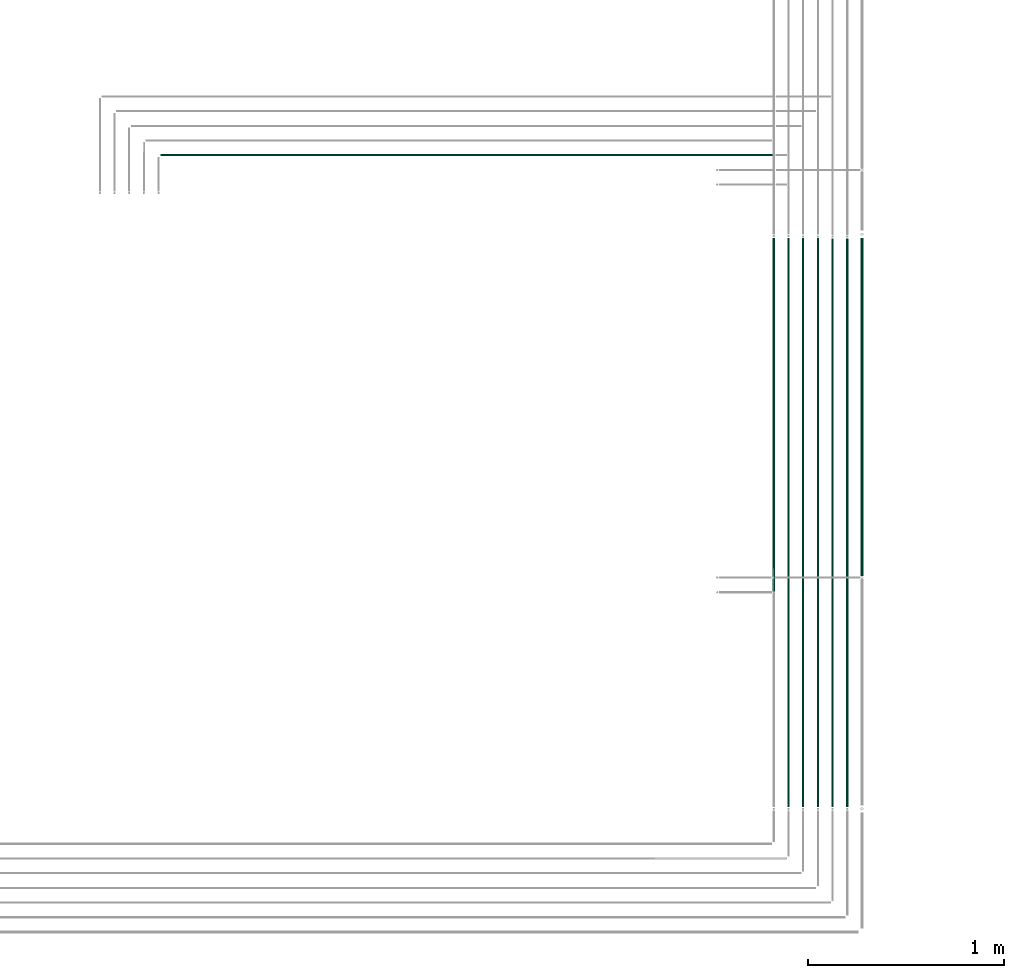
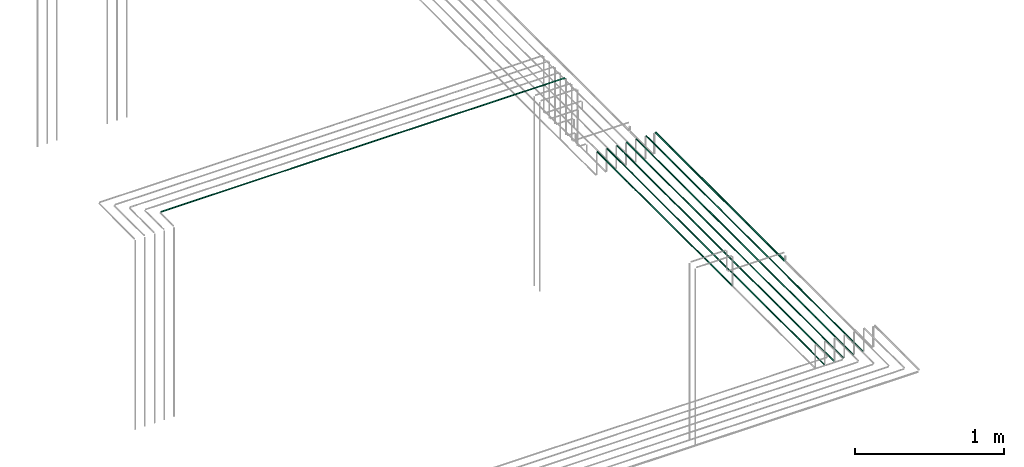
# One storey, part 18 of 89: 8 flow segments.
"""IFC2X3 building model written with IfcOpenShell, lengths in millimetres."""

from ifc_helpers import new_model, entity, si_unit, converted_unit, derived_unit, direction, frame, frame_2d, origin, origin_2d_with_axis, place, context, subcontext, project, spatial, circle, extrude, type_object, element, save


model = new_model("IFC2X3")

# Units and contexts
model_context = context("Model", 3, precision=0.01, world=origin(), true_north=direction((6.12303176911189e-17, 1.0)))
body_context = subcontext(model_context, "Body", "Model", "MODEL_VIEW")
ifc_project = project(units=[si_unit("LENGTHUNIT", "METRE", prefix="MILLI"), si_unit("AREAUNIT", "SQUARE_METRE"), si_unit("VOLUMEUNIT", "CUBIC_METRE"), converted_unit("PLANEANGLEUNIT", "DEGREE", entity("IfcRatioMeasure", 0.0174532925199433), si_unit("PLANEANGLEUNIT", "RADIAN"), dimensions=[0, 0, 0, 0, 0, 0, 0]), si_unit("MASSUNIT", "GRAM", prefix="KILO"), derived_unit("MASSDENSITYUNIT", [(si_unit("MASSUNIT", "GRAM", prefix="KILO"), 1), (si_unit("LENGTHUNIT", "METRE"), -3)]), derived_unit("MOMENTOFINERTIAUNIT", [(si_unit("LENGTHUNIT", "METRE"), 4)]), si_unit("TIMEUNIT", "SECOND"), si_unit("FREQUENCYUNIT", "HERTZ"), si_unit("THERMODYNAMICTEMPERATUREUNIT", "DEGREE_CELSIUS"), derived_unit("THERMALTRANSMITTANCEUNIT", [(si_unit("MASSUNIT", "GRAM", prefix="KILO"), 1), (si_unit("THERMODYNAMICTEMPERATUREUNIT", "KELVIN"), -1), (si_unit("TIMEUNIT", "SECOND"), -3)]), derived_unit("VOLUMETRICFLOWRATEUNIT", [(si_unit("LENGTHUNIT", "METRE"), 3), (si_unit("TIMEUNIT", "SECOND"), -1)]), derived_unit("MASSFLOWRATEUNIT", [(si_unit("MASSUNIT", "GRAM", prefix="KILO"), 1), (si_unit("TIMEUNIT", "SECOND"), -1)]), derived_unit("ROTATIONALFREQUENCYUNIT", [(si_unit("TIMEUNIT", "SECOND"), -1)]), si_unit("ELECTRICCURRENTUNIT", "AMPERE"), si_unit("ELECTRICVOLTAGEUNIT", "VOLT"), si_unit("POWERUNIT", "WATT"), si_unit("FORCEUNIT", "NEWTON", prefix="KILO"), si_unit("ILLUMINANCEUNIT", "LUX"), si_unit("LUMINOUSFLUXUNIT", "LUMEN"), si_unit("LUMINOUSINTENSITYUNIT", "CANDELA"), derived_unit("USERDEFINED", [(si_unit("MASSUNIT", "GRAM", prefix="KILO"), -1), (si_unit("LENGTHUNIT", "METRE"), -2), (si_unit("TIMEUNIT", "SECOND"), 3), (si_unit("LUMINOUSFLUXUNIT", "LUMEN"), 1)]), derived_unit("LINEARVELOCITYUNIT", [(si_unit("LENGTHUNIT", "METRE"), 1), (si_unit("TIMEUNIT", "SECOND"), -1)]), si_unit("PRESSUREUNIT", "PASCAL"), derived_unit("USERDEFINED", [(si_unit("LENGTHUNIT", "METRE"), -2), (si_unit("MASSUNIT", "GRAM", prefix="KILO"), 1), (si_unit("TIMEUNIT", "SECOND"), -2)]), derived_unit("LINEARFORCEUNIT", [(si_unit("MASSUNIT", "GRAM", prefix="KILO"), 1), (si_unit("LENGTHUNIT", "METRE"), 1), (si_unit("TIMEUNIT", "SECOND"), -2), (si_unit("LENGTHUNIT", "METRE"), -1)]), derived_unit("PLANARFORCEUNIT", [(si_unit("MASSUNIT", "GRAM", prefix="KILO"), 1), (si_unit("LENGTHUNIT", "METRE"), 1), (si_unit("TIMEUNIT", "SECOND"), -2), (si_unit("LENGTHUNIT", "METRE"), -2)])], contexts=[model_context])

# Site, building, storey
site_placement = place(None, frame((0.0, -0.00077364408347762, 0.0)))
site = spatial("IfcSite", under=ifc_project, at=site_placement, CompositionType="ELEMENT")
building_placement = place(site_placement, origin())
building = spatial("IfcBuilding", under=site, at=building_placement, CompositionType="ELEMENT")
storey_placement = place(building_placement, frame((0.0, 0.0, 24000.0)))
storey = spatial("IfcBuildingStorey", under=building, at=storey_placement, CompositionType="ELEMENT", Elevation=24000.0)

# Flow segments
pipe_segment_type = type_object("IfcPipeSegmentType", PredefinedType="NOTDEFINED")
flow_segment_1_placement = place(storey_placement, frame((67289.4049963189, 1813.24057780393, 2794.40472776409)))
element("IfcFlowSegment", 1, at=flow_segment_1_placement, inside=storey, type_object=pipe_segment_type, context=body_context, shape_type="SweptSolid", body=[
    extrude(circle(Radius=4.0, at=frame_2d((8.66293703438714e-12, 0.0), x_axis=(1.0, 0.0))), frame((5.59527223591499, 0.0, 5.59527223591499), z_axis=(0.0, 1.0, 0.0), x_axis=(-1.0, 0.0, 0.0)), (0.0, 0.0, 1.0), 2902.18521069678),
])
flow_segment_2_placement = place(storey_placement, frame((67364.4049963189, 1813.24057780393, 2794.40472776409)))
element("IfcFlowSegment", 2, at=flow_segment_2_placement, inside=storey, type_object=pipe_segment_type, context=body_context, shape_type="SweptSolid", body=[
    extrude(circle(Radius=4.0, at=origin_2d_with_axis()), frame((5.59527223591499, 0.0, 5.59527223591499), z_axis=(0.0, 1.0, 0.0), x_axis=(-1.0, 0.0, 0.0)), (0.0, 0.0, 1.0), 2900.36521628995),
])
flow_segment_3_placement = place(storey_placement, frame((67439.4049963189, 1813.24057780393, 2794.40472776409)))
element("IfcFlowSegment", 3, at=flow_segment_3_placement, inside=storey, type_object=pipe_segment_type, context=body_context, shape_type="SweptSolid", body=[
    extrude(circle(Radius=4.0, at=frame_2d((8.66293703438714e-12, 0.0), x_axis=(1.0, 0.0))), frame((5.59527223591499, 0.0, 5.59527223591499), z_axis=(0.0, 1.0, 0.0), x_axis=(-1.0, 0.0, 0.0)), (0.0, 0.0, 1.0), 2900.36521628995),
])
flow_segment_4_placement = place(storey_placement, frame((67514.4049963189, 1813.24057780393, 2794.40472776409)))
element("IfcFlowSegment", 4, at=flow_segment_4_placement, inside=storey, type_object=pipe_segment_type, context=body_context, shape_type="SweptSolid", body=[
    extrude(circle(Radius=4.0, at=frame_2d((8.66293703438714e-12, 0.0), x_axis=(1.0, 0.0))), frame((5.59527223591499, 0.0, 5.59527223591499), z_axis=(0.0, 1.0, 0.0), x_axis=(-1.0, 0.0, 0.0)), (0.0, 0.0, 1.0), 2899.45521908654),
])
flow_segment_5_placement = place(storey_placement, frame((67589.4049963189, 1813.24057780393, 2794.40472776409)))
element("IfcFlowSegment", 5, at=flow_segment_5_placement, inside=storey, type_object=pipe_segment_type, context=body_context, shape_type="SweptSolid", body=[
    extrude(circle(Radius=4.0, at=frame_2d((8.66293703438714e-12, 0.0), x_axis=(1.0, 0.0))), frame((5.59527223592365, 0.0, 5.59527223591499), z_axis=(0.0, 1.0, 0.0), x_axis=(-1.0, 0.0, 0.0)), (0.0, 0.0, 1.0), 2899.45521908654),
])
flow_segment_6_placement = place(storey_placement, frame((64091.1933873496, 5132.64530556804, 3144.40472776411)))
element("IfcFlowSegment", 6, at=flow_segment_6_placement, inside=storey, type_object=pipe_segment_type, context=body_context, shape_type="SweptSolid", body=[
    extrude(circle(Radius=4.0, at=origin_2d_with_axis()), frame((0.0, 5.5952722359269, 5.59527223591499), z_axis=(1.0, 0.0, 0.0), x_axis=(0.0, -1.0, 0.0)), (0.0, 0.0, 1.0), 3120.08853919053),
])
flow_segment_7_placement = place(storey_placement, frame((67214.4049963189, 2913.24057780394, 2794.4047277641)))
element("IfcFlowSegment", 7, at=flow_segment_7_placement, inside=storey, type_object=pipe_segment_type, context=body_context, shape_type="SweptSolid", body=[
    extrude(circle(Radius=4.0, at=origin_2d_with_axis()), frame((5.59527223591499, 0.0, 5.59527223591499), z_axis=(0.0, 1.0, 0.0), x_axis=(1.0, 0.0, 0.0)), (0.0, 0.0, 1.0), 1802.18521069676),
])
flow_segment_8_placement = place(storey_placement, frame((67660.9049963189, 2991.24057780394, 2790.90472776409)))
element("IfcFlowSegment", 8, at=flow_segment_8_placement, inside=storey, type_object=pipe_segment_type, context=body_context, shape_type="SweptSolid", body=[
    extrude(circle(Radius=7.5, at=origin_2d_with_axis()), frame((9.09527223591419, 0.0, 9.09527223591419), z_axis=(0.0, 1.0, 0.0), x_axis=(1.0, 0.0, 0.0)), (0.0, 0.0, 1.0), 1725.5452218831),
])

save(model, "model.ifc")
